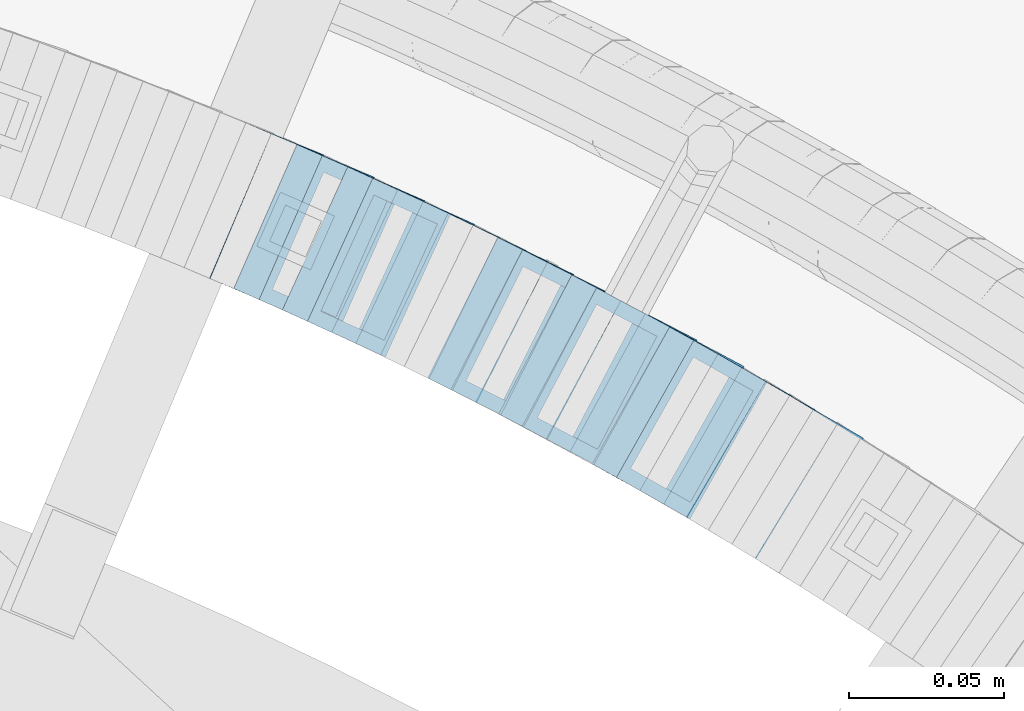
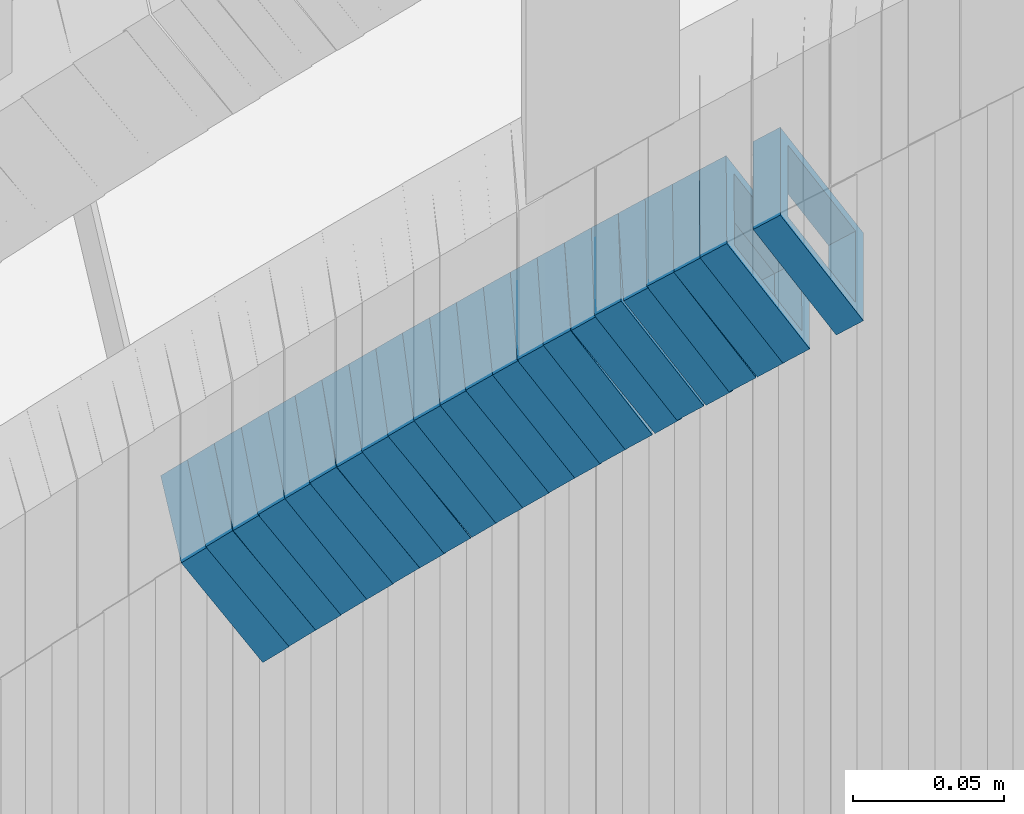
# One storey, part 752 of 975: 22 members.
"""IFC2X3 building model written with IfcOpenShell, lengths in millimetres."""

from ifc_helpers import new_model, si_unit, frame, origin_with_axes, place, context, subcontext, project, spatial, faceted_brep, material, type_object, element, save


model = new_model("IFC2X3")

# Units and contexts
model_context = context("Model", 3, precision=1e-05, world=origin_with_axes())
body_context = subcontext(model_context, "Body", "Model", "MODEL_VIEW")
ifc_project = project(units=[si_unit("LENGTHUNIT", "METRE", prefix="MILLI"), si_unit("AREAUNIT", "SQUARE_METRE"), si_unit("VOLUMEUNIT", "CUBIC_METRE"), si_unit("MASSUNIT", "GRAM", prefix="KILO"), si_unit("TIMEUNIT", "SECOND"), si_unit("PLANEANGLEUNIT", "RADIAN"), si_unit("SOLIDANGLEUNIT", "STERADIAN"), si_unit("THERMODYNAMICTEMPERATUREUNIT", "DEGREE_CELSIUS"), si_unit("LUMINOUSINTENSITYUNIT", "LUMEN")], contexts=[model_context])

# Site, building, storey
site_placement = place(None, origin_with_axes())
site = spatial("IfcSite", under=ifc_project, at=site_placement, CompositionType="ELEMENT")
building_placement = place(site_placement, origin_with_axes())
building = spatial("IfcBuilding", under=site, at=building_placement, Name="Undefined", CompositionType="ELEMENT")
storey_placement = place(building_placement, origin_with_axes())
storey = spatial("IfcBuildingStorey", under=building, at=storey_placement, Name="Undefined", CompositionType="ELEMENT", Elevation=0.0)

# Members
ifc_material = material()
member_type = type_object("IfcMemberType", Name="HSS2X2X.188_TUBES", PredefinedType="NOTDEFINED")
member_1_placement = place(storey_placement, frame((35434.9974360442, 4612.49057627026, 1515.73278679352), z_axis=(0.496138938203221, 0.868243142212238, 4.57307578471955e-11), x_axis=(0.730391194976154, -0.417366396986292, 0.540679195982226)))
element("IfcMember", 1, at=member_1_placement, inside=storey, type_object=member_type, material=ifc_material, Name="WALL", ObjectType="HSS2X2X.188_TUBES", context=body_context, shape_type="Brep", body=[
    faceted_brep([(0.0, 20.6374999999753, -20.6375000000298), (0.0, -20.6375000000153, -20.6375000000153), (10.5422957651572, -20.6374999999771, -20.6374999999534), (10.5422957651481, 20.6375000000153, -20.6374999999789), (0.0, -20.6374999999825, 20.6375000000335), (10.5422957651535, -20.6374999999971, 20.6375000000298), (0.0, 20.6375000000116, 20.6375000000189), (10.5422957651444, 20.6374999999971, 20.6375000000044), (0.0, 25.3999999999724, -25.4000000000342), (0.0, 25.400000000016, 25.4000000000196), (10.5422957651426, 25.3999999999924, 25.3999999999905), (10.5422957651463, 25.4000000000178, -25.3999999999833), (0.0, -25.399999999976, 25.4000000000378), (10.5422957651499, -25.3999999999996, 25.4000000000269), (0.0, -25.400000000016, -25.4000000000196), (10.5422957651554, -25.3999999999742, -25.3999999999469)], [[[0, 1, 2, 3]], [[1, 4, 5, 2]], [[4, 6, 7, 5]], [[6, 0, 3, 7]], [[8, 9, 10, 11]], [[9, 12, 13, 10]], [[12, 14, 15, 13]], [[14, 8, 11, 15]], [[13, 15, 11, 10], [5, 7, 3, 2]], [[14, 12, 9, 8], [6, 4, 1, 0]]]),
])
member_2_placement = place(storey_placement, frame((35450.2959705193, 4603.58334832504, 1527.14601812941), z_axis=(0.499722453606285, 0.866185585981269, 3.44271711583132e-10), x_axis=(0.728209106903487, -0.420120638944157, 0.541488822928026)))
element("IfcMember", 2, at=member_2_placement, inside=storey, type_object=member_type, material=ifc_material, Name="WALL", ObjectType="HSS2X2X.188_TUBES", context=body_context, shape_type="Brep", body=[
    faceted_brep([(0.0, 20.6374999999753, -20.6375000000298), (0.0, -20.6375000000153, -20.6375000000153), (10.7093417165161, -20.637499999968, -20.6374999999534), (10.709341716436, 20.6374999999898, -20.6375000000116), (0.0, -20.6374999999825, 20.6375000000335), (10.7093417164688, -20.6374999999971, 20.6375000000153), (0.0, 20.6375000000116, 20.6375000000189), (10.7093417163924, 20.6374999999643, 20.6374999999571), (0.0, 25.3999999999724, -25.4000000000342), (0.0, 25.400000000016, 25.4000000000196), (10.7093417163815, 25.3999999999542, 25.3999999999469), (10.7093417164288, 25.3999999999869, -25.4000000000196), (0.0, -25.399999999976, 25.4000000000378), (10.7093417164724, -25.3999999999942, 25.4000000000196), (0.0, -25.400000000016, -25.4000000000196), (10.709341716527, -25.3999999999578, -25.3999999999432)], [[[0, 1, 2, 3]], [[1, 4, 5, 2]], [[4, 6, 7, 5]], [[6, 0, 3, 7]], [[8, 9, 10, 11]], [[9, 12, 13, 10]], [[12, 14, 15, 13]], [[14, 8, 11, 15]], [[13, 15, 11, 10], [5, 7, 3, 2]], [[14, 12, 9, 8], [6, 4, 1, 0]]]),
])
member_3_placement = place(storey_placement, frame((35427.4220188738, 4616.85079483736, 1509.9806746727), z_axis=(0.491321186669673, 0.870978467890857, -1.51605718201608e-10), x_axis=(0.731050131101486, -0.412387253057095, 0.543601379075259)))
element("IfcMember", 3, at=member_3_placement, inside=storey, type_object=member_type, material=ifc_material, Name="WALL", ObjectType="HSS2X2X.188_TUBES", context=body_context, shape_type="Brep", body=[
    faceted_brep([(0.0, 20.6374999999753, -20.6375000000298), (0.0, -20.6375000000153, -20.6375000000153), (10.6709887076922, -20.6374999999844, -20.6374999999825), (10.6709887076995, 20.6375000000171, -20.6374999999753), (0.0, -20.6374999999825, 20.6375000000335), (10.6709887076922, -20.6374999999971, 20.6375000000153), (0.0, 20.6375000000116, 20.6375000000189), (10.6709887076941, 20.6375000000025, 20.6375000000189), (0.0, 25.3999999999724, -25.4000000000342), (0.0, 25.400000000016, 25.4000000000196), (10.6709887076959, 25.3999999999996, 25.4000000000233), (10.6709887077013, 25.4000000000178, -25.3999999999724), (0.0, -25.399999999976, 25.4000000000378), (10.6709887076904, -25.3999999999978, 25.400000000016), (0.0, -25.400000000016, -25.4000000000196), (10.6709887076959, -25.3999999999796, -25.3999999999796)], [[[0, 1, 2, 3]], [[1, 4, 5, 2]], [[4, 6, 7, 5]], [[6, 0, 3, 7]], [[8, 9, 10, 11]], [[9, 12, 13, 10]], [[12, 14, 15, 13]], [[14, 8, 11, 15]], [[13, 15, 11, 10], [5, 7, 3, 2]], [[14, 12, 9, 8], [6, 4, 1, 0]]]),
])
member_4_placement = place(storey_placement, frame((35419.4748254217, 4621.33382704107, 1504.17216907421), z_axis=(0.491321186669673, 0.870978467890857, -1.51605718201608e-10), x_axis=(0.734770841275006, -0.414486115154973, 0.536947922200801)))
element("IfcMember", 4, at=member_4_placement, inside=storey, type_object=member_type, material=ifc_material, Name="WALL", ObjectType="HSS2X2X.188_TUBES", context=body_context, shape_type="Brep", body=[
    faceted_brep([(0.0, 20.6374999999753, -20.6375000000298), (0.0, -20.6375000000153, -20.6375000000153), (10.6216759506497, -20.637499999968, -20.6374999999534), (10.6216759506497, 20.6375000000262, -20.6374999999643), (0.0, -20.6374999999825, 20.6375000000335), (10.6216759506169, -20.6374999999935, 20.637500000008), (0.0, 20.6375000000116, 20.6375000000189), (10.6216759506242, 20.6375000000007, 20.6374999999971), (0.0, 25.3999999999724, -25.4000000000342), (0.0, 25.400000000016, 25.4000000000196), (10.6216759506169, 25.3999999999978, 25.3999999999869), (10.6216759506533, 25.4000000000269, -25.3999999999614), (0.0, -25.399999999976, 25.4000000000378), (10.6216759506242, -25.3999999999942, 25.4000000000051), (0.0, -25.400000000016, -25.4000000000196), (10.6216759506569, -25.3999999999614, -25.3999999999432)], [[[0, 1, 2, 3]], [[1, 4, 5, 2]], [[4, 6, 7, 5]], [[6, 0, 3, 7]], [[8, 9, 10, 11]], [[9, 12, 13, 10]], [[12, 14, 15, 13]], [[14, 8, 11, 15]], [[13, 15, 11, 10], [5, 7, 3, 2]], [[14, 12, 9, 8], [6, 4, 1, 0]]]),
])
member_5_placement = place(storey_placement, frame((35412.3025046159, 4625.52354750214, 1498.4779549158), z_axis=(0.469427602090153, 0.882970965771746, 1.18974867291399e-10), x_axis=(0.744686765943849, -0.3959094199702, 0.537305640959548)))
element("IfcMember", 5, at=member_5_placement, inside=storey, type_object=member_type, material=ifc_material, Name="WALL", ObjectType="HSS2X2X.188_TUBES", context=body_context, shape_type="Brep", body=[
    faceted_brep([(0.0, 20.6374999999753, -20.6375000000298), (0.0, -20.6375000000153, -20.6375000000153), (10.6061303028146, -20.6374999999571, -20.6374999999643), (10.6061303027491, 20.6374999999971, -20.6375000000007), (0.0, -20.6374999999825, 20.6375000000335), (10.6061303027855, -20.6374999999825, 20.6375000000116), (0.0, 20.6375000000116, 20.6375000000189), (10.6061303027236, 20.637499999968, 20.6374999999716), (0.0, 25.3999999999724, -25.4000000000342), (0.0, 25.400000000016, 25.4000000000196), (10.6061303027163, 25.3999999999651, 25.3999999999651), (10.6061303027454, 25.3999999999942, -25.4000000000051), (0.0, -25.399999999976, 25.4000000000378), (10.6061303027891, -25.3999999999796, 25.4000000000124), (0.0, -25.400000000016, -25.4000000000196), (10.6061303028182, -25.3999999999505, -25.3999999999542)], [[[0, 1, 2, 3]], [[1, 4, 5, 2]], [[4, 6, 7, 5]], [[6, 0, 3, 7]], [[8, 9, 10, 11]], [[9, 12, 13, 10]], [[12, 14, 15, 13]], [[14, 8, 11, 15]], [[13, 15, 11, 10], [5, 7, 3, 2]], [[14, 12, 9, 8], [6, 4, 1, 0]]]),
])
member_6_placement = place(storey_placement, frame((35404.1030910584, 4629.80376584595, 1492.80596512413), z_axis=(0.482780509040982, 0.875741388818714, 7.89789282862329e-11), x_axis=(0.737623694251243, -0.406638703138413, 0.539032699183508)))
element("IfcMember", 6, at=member_6_placement, inside=storey, type_object=member_type, material=ifc_material, Name="WALL", ObjectType="HSS2X2X.188_TUBES", context=body_context, shape_type="Brep", body=[
    faceted_brep([(0.0, 20.6374999999753, -20.6375000000298), (0.0, -20.6375000000153, -20.6375000000153), (10.5744976239494, -20.6375000000207, -20.6375000000335), (10.5744976239657, 20.6375000000098, -20.637500000008), (0.0, -20.6374999999825, 20.6375000000335), (10.5744976239639, -20.6375000000244, 20.6374999999753), (0.0, 20.6375000000116, 20.6375000000189), (10.5744976239803, 20.6374999999989, 20.6374999999935), (0.0, 25.3999999999724, -25.4000000000342), (0.0, 25.400000000016, 25.4000000000196), (10.5744976239857, 25.4000000000051, 25.4000000000015), (10.5744976239675, 25.4000000000124, -25.4000000000051), (0.0, -25.399999999976, 25.4000000000378), (10.5744976239639, -25.4000000000287, 25.3999999999724), (0.0, -25.400000000016, -25.4000000000196), (10.5744976239494, -25.4000000000215, -25.4000000000378)], [[[0, 1, 2, 3]], [[1, 4, 5, 2]], [[4, 6, 7, 5]], [[6, 0, 3, 7]], [[8, 9, 10, 11]], [[9, 12, 13, 10]], [[12, 14, 15, 13]], [[14, 8, 11, 15]], [[13, 15, 11, 10], [5, 7, 3, 2]], [[14, 12, 9, 8], [6, 4, 1, 0]]]),
])
member_7_placement = place(storey_placement, frame((35397.0835716603, 4633.82500833659, 1487.11953505789), z_axis=(0.46064508089183, 0.887584423843816, -1.56837813847233e-11), x_axis=(0.743630284592201, -0.38593470478849, 0.545956411700736)))
element("IfcMember", 7, at=member_7_placement, inside=storey, type_object=member_type, material=ifc_material, Name="WALL", ObjectType="HSS2X2X.188_TUBES", context=body_context, shape_type="Brep", body=[
    faceted_brep([(0.0, 20.6374999999753, -20.6375000000298), (0.0, -20.6375000000153, -20.6375000000153), (10.6216759506497, -20.637499999968, -20.6374999999534), (10.6216759506497, 20.6375000000262, -20.6374999999643), (0.0, -20.6374999999825, 20.6375000000335), (10.6216759506169, -20.6374999999935, 20.637500000008), (0.0, 20.6375000000116, 20.6375000000189), (10.6216759506242, 20.6375000000007, 20.6374999999971), (0.0, 25.3999999999724, -25.4000000000342), (0.0, 25.400000000016, 25.4000000000196), (10.6216759506169, 25.3999999999978, 25.3999999999869), (10.6216759506533, 25.4000000000269, -25.3999999999614), (0.0, -25.399999999976, 25.4000000000378), (10.6216759506242, -25.3999999999942, 25.4000000000051), (0.0, -25.400000000016, -25.4000000000196), (10.6216759506569, -25.3999999999614, -25.3999999999432)], [[[0, 1, 2, 3]], [[1, 4, 5, 2]], [[4, 6, 7, 5]], [[6, 0, 3, 7]], [[8, 9, 10, 11]], [[9, 12, 13, 10]], [[12, 14, 15, 13]], [[14, 8, 11, 15]], [[13, 15, 11, 10], [5, 7, 3, 2]], [[14, 12, 9, 8], [6, 4, 1, 0]]]),
])
member_8_placement = place(storey_placement, frame((35388.6678405396, 4638.16894075791, 1481.2174760001), z_axis=(0.464833898973127, 0.88539790284676, 2.99266957881628e-11), x_axis=(0.748841799918479, -0.393141944957117, 0.533549781941843)))
element("IfcMember", 8, at=member_8_placement, inside=storey, type_object=member_type, material=ifc_material, Name="WALL", ObjectType="HSS2X2X.188_TUBES", context=body_context, shape_type="Brep", body=[
    faceted_brep([(0.0, 20.6374999999753, -20.6375000000298), (0.0, -20.6375000000153, -20.6375000000153), (10.6831643251735, -20.6375000000498, -20.6375000000953), (10.6831643252044, 20.637499999988, -20.6375000000226), (0.0, -20.6374999999825, 20.6375000000335), (10.6831643251935, -20.6375000000135, 20.637499999968), (0.0, 20.6375000000116, 20.6375000000189), (10.6831643252244, 20.6375000000226, 20.6375000000407), (0.0, 25.3999999999724, -25.4000000000342), (0.0, 25.400000000016, 25.4000000000196), (10.6831643252317, 25.4000000000306, 25.4000000000597), (10.6831643252044, 25.3999999999905, -25.4000000000196), (0.0, -25.399999999976, 25.4000000000378), (10.6831643251917, -25.400000000016, 25.3999999999614), (0.0, -25.400000000016, -25.4000000000196), (10.6831643251644, -25.400000000056, -25.4000000001179)], [[[0, 1, 2, 3]], [[1, 4, 5, 2]], [[4, 6, 7, 5]], [[6, 0, 3, 7]], [[8, 9, 10, 11]], [[9, 12, 13, 10]], [[12, 14, 15, 13]], [[14, 8, 11, 15]], [[13, 15, 11, 10], [5, 7, 3, 2]], [[14, 12, 9, 8], [6, 4, 1, 0]]]),
])
member_9_placement = place(storey_placement, frame((35381.0334607013, 4642.20291402418, 1475.61027951396), z_axis=(0.46064508089183, 0.887584423843816, -1.56837813847233e-11), x_axis=(0.747448139909826, -0.387916122952996, 0.539298024934689)))
element("IfcMember", 9, at=member_9_placement, inside=storey, type_object=member_type, material=ifc_material, Name="WALL", ObjectType="HSS2X2X.188_TUBES", context=body_context, shape_type="Brep", body=[
    faceted_brep([(0.0, 20.6374999999753, -20.6375000000298), (0.0, -20.6375000000153, -20.6375000000153), (10.5744976239494, -20.6375000000207, -20.6375000000335), (10.5744976239657, 20.6375000000098, -20.637500000008), (0.0, -20.6374999999825, 20.6375000000335), (10.5744976239639, -20.6375000000244, 20.6374999999753), (0.0, 20.6375000000116, 20.6375000000189), (10.5744976239803, 20.6374999999989, 20.6374999999935), (0.0, 25.3999999999724, -25.4000000000342), (0.0, 25.400000000016, 25.4000000000196), (10.5744976239857, 25.4000000000051, 25.4000000000015), (10.5744976239675, 25.4000000000124, -25.4000000000051), (0.0, -25.399999999976, 25.4000000000378), (10.5744976239639, -25.4000000000287, 25.3999999999724), (0.0, -25.400000000016, -25.4000000000196), (10.5744976239494, -25.4000000000215, -25.4000000000378)], [[[0, 1, 2, 3]], [[1, 4, 5, 2]], [[4, 6, 7, 5]], [[6, 0, 3, 7]], [[8, 9, 10, 11]], [[9, 12, 13, 10]], [[12, 14, 15, 13]], [[14, 8, 11, 15]], [[13, 15, 11, 10], [5, 7, 3, 2]], [[14, 12, 9, 8], [6, 4, 1, 0]]]),
])
member_10_placement = place(storey_placement, frame((35373.4258024925, 4646.23437016647, 1469.87988730664), z_axis=(0.447213595463116, 0.894427191018337, -1.29375166579848e-10), x_axis=(0.754280757630217, -0.377140378815194, 0.53742503973663)))
element("IfcMember", 10, at=member_10_placement, inside=storey, type_object=member_type, material=ifc_material, Name="WALL", ObjectType="HSS2X2X.188_TUBES", context=body_context, shape_type="Brep", body=[
    faceted_brep([(0.0, 20.6374999999753, -20.6375000000298), (0.0, -20.6375000000153, -20.6375000000153), (10.6061303028146, -20.6374999999571, -20.6374999999643), (10.6061303027491, 20.6374999999971, -20.6375000000007), (0.0, -20.6374999999825, 20.6375000000335), (10.6061303027855, -20.6374999999825, 20.6375000000116), (0.0, 20.6375000000116, 20.6375000000189), (10.6061303027236, 20.637499999968, 20.6374999999716), (0.0, 25.3999999999724, -25.4000000000342), (0.0, 25.400000000016, 25.4000000000196), (10.6061303027163, 25.3999999999651, 25.3999999999651), (10.6061303027454, 25.3999999999942, -25.4000000000051), (0.0, -25.399999999976, 25.4000000000378), (10.6061303027891, -25.3999999999796, 25.4000000000124), (0.0, -25.400000000016, -25.4000000000196), (10.6061303028182, -25.3999999999505, -25.3999999999542)], [[[0, 1, 2, 3]], [[1, 4, 5, 2]], [[4, 6, 7, 5]], [[6, 0, 3, 7]], [[8, 9, 10, 11]], [[9, 12, 13, 10]], [[12, 14, 15, 13]], [[14, 8, 11, 15]], [[13, 15, 11, 10], [5, 7, 3, 2]], [[14, 12, 9, 8], [6, 4, 1, 0]]]),
])
member_11_placement = place(storey_placement, frame((35365.5769820395, 4650.15878039297, 1464.1885452034), z_axis=(0.447213595463116, 0.894427191018337, -1.29375166579848e-10), x_axis=(0.750454514252734, -0.375227257126282, 0.544079523183129)))
element("IfcMember", 11, at=member_11_placement, inside=storey, type_object=member_type, material=ifc_material, Name="WALL", ObjectType="HSS2X2X.188_TUBES", context=body_context, shape_type="Brep", body=[
    faceted_brep([(0.0, 20.6374999999753, -20.6375000000298), (0.0, -20.6375000000153, -20.6375000000153), (10.6625512894789, -20.6374999999625, -20.6374999999389), (10.6625512893879, 20.6374999999789, -20.6375000000371), (0.0, -20.6374999999825, 20.6375000000335), (10.6625512894352, -20.6374999999989, 20.6375000000153), (0.0, 20.6375000000116, 20.6375000000189), (10.6625512893443, 20.6374999999443, 20.6374999999134), (0.0, 25.3999999999724, -25.4000000000342), (0.0, 25.400000000016, 25.4000000000196), (10.6625512893297, 25.3999999999342, 25.3999999998996), (10.6625512893916, 25.399999999976, -25.4000000000415), (0.0, -25.399999999976, 25.4000000000378), (10.6625512894389, -25.399999999996, 25.400000000016), (0.0, -25.400000000016, -25.4000000000196), (10.6625512894971, -25.3999999999523, -25.3999999999214)], [[[0, 1, 2, 3]], [[1, 4, 5, 2]], [[4, 6, 7, 5]], [[6, 0, 3, 7]], [[8, 9, 10, 11]], [[9, 12, 13, 10]], [[12, 14, 15, 13]], [[14, 8, 11, 15]], [[13, 15, 11, 10], [5, 7, 3, 2]], [[14, 12, 9, 8], [6, 4, 1, 0]]]),
])
member_12_placement = place(storey_placement, frame((35357.7587392916, 4654.12325477763, 1458.41067219573), z_axis=(0.438202247109097, 0.898876404534315, -8.71484644449083e-11), x_axis=(0.756943389157146, -0.369009902076447, 0.539322165111749)))
element("IfcMember", 12, at=member_12_placement, inside=storey, type_object=member_type, material=ifc_material, Name="WALL", ObjectType="HSS2X2X.188_TUBES", context=body_context, shape_type="Brep", body=[
    faceted_brep([(0.0, 20.6374999999753, -20.6375000000298), (0.0, -20.6375000000153, -20.6375000000153), (10.5744976239494, -20.6375000000207, -20.6375000000335), (10.5744976239657, 20.6375000000098, -20.637500000008), (0.0, -20.6374999999825, 20.6375000000335), (10.5744976239639, -20.6375000000244, 20.6374999999753), (0.0, 20.6375000000116, 20.6375000000189), (10.5744976239803, 20.6374999999989, 20.6374999999935), (0.0, 25.3999999999724, -25.4000000000342), (0.0, 25.400000000016, 25.4000000000196), (10.5744976239857, 25.4000000000051, 25.4000000000015), (10.5744976239675, 25.4000000000124, -25.4000000000051), (0.0, -25.399999999976, 25.4000000000378), (10.5744976239639, -25.4000000000287, 25.3999999999724), (0.0, -25.400000000016, -25.4000000000196), (10.5744976239494, -25.4000000000215, -25.4000000000378)], [[[0, 1, 2, 3]], [[1, 4, 5, 2]], [[4, 6, 7, 5]], [[6, 0, 3, 7]], [[8, 9, 10, 11]], [[9, 12, 13, 10]], [[12, 14, 15, 13]], [[14, 8, 11, 15]], [[13, 15, 11, 10], [5, 7, 3, 2]], [[14, 12, 9, 8], [6, 4, 1, 0]]]),
])
member_13_placement = place(storey_placement, frame((35342.1470448302, 4661.74378026491, 1447.05100239252), z_axis=(0.429056814647039, 0.903277504316883, -2.97829501505475e-10), x_axis=(0.75565911600651, -0.358938080003198, 0.547852859004933)))
element("IfcMember", 13, at=member_13_placement, inside=storey, type_object=member_type, material=ifc_material, Name="WALL", ObjectType="HSS2X2X.188_TUBES", context=body_context, shape_type="Brep", body=[
    faceted_brep([(0.0, 20.6374999999753, -20.6375000000298), (0.0, -20.6375000000153, -20.6375000000153), (10.5948100501191, -20.6375000000335, -20.6375000000844), (10.5948100501555, 20.6374999999971, -20.6375000000116), (0.0, -20.6374999999825, 20.6375000000335), (10.5948100501446, -20.6375000000098, 20.6374999999571), (0.0, 20.6375000000116, 20.6375000000189), (10.5948100501828, 20.6375000000189, 20.6375000000298), (0.0, 25.3999999999724, -25.4000000000342), (0.0, 25.400000000016, 25.4000000000196), (10.5948100501919, 25.4000000000251, 25.4000000000451), (10.5948100501591, 25.3999999999978, -25.4000000000051), (0.0, -25.399999999976, 25.4000000000378), (10.5948100501482, -25.4000000000106, 25.3999999999578), (0.0, -25.400000000016, -25.4000000000196), (10.5948100501118, -25.4000000000378, -25.400000000096)], [[[0, 1, 2, 3]], [[1, 4, 5, 2]], [[4, 6, 7, 5]], [[6, 0, 3, 7]], [[8, 9, 10, 11]], [[9, 12, 13, 10]], [[12, 14, 15, 13]], [[14, 8, 11, 15]], [[13, 15, 11, 10], [5, 7, 3, 2]], [[14, 12, 9, 8], [6, 4, 1, 0]]]),
])
member_14_placement = place(storey_placement, frame((35349.7112724843, 4658.07173522613, 1452.64843312844), z_axis=(0.433815618951201, 0.901001669673251, 6.19982074567816e-11), x_axis=(0.760940849966011, -0.366378927983755, 0.535476893976275)))
element("IfcMember", 14, at=member_14_placement, inside=storey, type_object=member_type, material=ifc_material, Name="WALL", ObjectType="HSS2X2X.188_TUBES", context=body_context, shape_type="Brep", body=[
    faceted_brep([(0.0, 20.6374999999753, -20.6375000000298), (0.0, -20.6375000000153, -20.6375000000153), (10.6395488625676, -20.6374999999771, -20.6374999999716), (10.6395488625531, 20.6374999999916, -20.6375000000189), (0.0, -20.6374999999825, 20.6375000000335), (10.6395488625731, -20.6374999999844, 20.6375000000153), (0.0, 20.6375000000116, 20.6375000000189), (10.6395488625585, 20.6374999999825, 20.637499999968), (0.0, 25.3999999999724, -25.4000000000342), (0.0, 25.400000000016, 25.4000000000196), (10.6395488625567, 25.3999999999778, 25.3999999999614), (10.6395488625494, 25.3999999999887, -25.4000000000233), (0.0, -25.399999999976, 25.4000000000378), (10.6395488625749, -25.3999999999851, 25.400000000016), (0.0, -25.400000000016, -25.4000000000196), (10.6395488625658, -25.399999999976, -25.3999999999687)], [[[0, 1, 2, 3]], [[1, 4, 5, 2]], [[4, 6, 7, 5]], [[6, 0, 3, 7]], [[8, 9, 10, 11]], [[9, 12, 13, 10]], [[12, 14, 15, 13]], [[14, 8, 11, 15]], [[13, 15, 11, 10], [5, 7, 3, 2]], [[14, 12, 9, 8], [6, 4, 1, 0]]]),
])
member_15_placement = place(storey_placement, frame((35333.9431458108, 4665.6659105841, 1441.17795491567), z_axis=(0.424720210825697, 0.905324661387381, 1.0447547538206e-10), x_axis=(0.763539595237658, -0.358203761111365, 0.537305641167097)))
element("IfcMember", 15, at=member_15_placement, inside=storey, type_object=member_type, material=ifc_material, Name="WALL", ObjectType="HSS2X2X.188_TUBES", context=body_context, shape_type="Brep", body=[
    faceted_brep([(0.0, 20.6374999999753, -20.6375000000298), (0.0, -20.6375000000153, -20.6375000000153), (10.6061303028146, -20.6374999999571, -20.6374999999643), (10.6061303027491, 20.6374999999971, -20.6375000000007), (0.0, -20.6374999999825, 20.6375000000335), (10.6061303027855, -20.6374999999825, 20.6375000000116), (0.0, 20.6375000000116, 20.6375000000189), (10.6061303027236, 20.637499999968, 20.6374999999716), (0.0, 25.3999999999724, -25.4000000000342), (0.0, 25.400000000016, 25.4000000000196), (10.6061303027163, 25.3999999999651, 25.3999999999651), (10.6061303027454, 25.3999999999942, -25.4000000000051), (0.0, -25.399999999976, 25.4000000000378), (10.6061303027891, -25.3999999999796, 25.4000000000124), (0.0, -25.400000000016, -25.4000000000196), (10.6061303028182, -25.3999999999505, -25.3999999999542)], [[[0, 1, 2, 3]], [[1, 4, 5, 2]], [[4, 6, 7, 5]], [[6, 0, 3, 7]], [[8, 9, 10, 11]], [[9, 12, 13, 10]], [[12, 14, 15, 13]], [[14, 8, 11, 15]], [[13, 15, 11, 10], [5, 7, 3, 2]], [[14, 12, 9, 8], [6, 4, 1, 0]]]),
])
member_16_placement = place(storey_placement, frame((35326.1202964446, 4669.41405141638, 1435.44425173907), z_axis=(0.411288866904863, 0.91150505646437, -1.75959485204658e-10), x_axis=(0.769961537257372, -0.347421669116229, 0.535217166179074)))
element("IfcMember", 16, at=member_16_placement, inside=storey, type_object=member_type, material=ifc_material, Name="WALL", ObjectType="HSS2X2X.188_TUBES", context=body_context, shape_type="Brep", body=[
    faceted_brep([(0.0, 20.6374999999753, -20.6375000000298), (0.0, -20.6375000000153, -20.6375000000153), (10.648004507897, -20.6374999999862, -20.637499999968), (10.6480045078188, 20.6374999999771, -20.6375000000808), (0.0, -20.6374999999825, 20.6375000000335), (10.6480045079406, -20.6374999999698, 20.6375000001062), (0.0, 20.6375000000116, 20.6375000000189), (10.6480045078679, 20.6374999999935, 20.6375000000007), (0.0, 25.3999999999724, -25.4000000000342), (0.0, 25.400000000016, 25.4000000000196), (10.6480045078661, 25.3999999999905, 25.4000000000015), (10.648004507806, 25.3999999999705, -25.4000000000997), (0.0, -25.399999999976, 25.4000000000378), (10.6480045079552, -25.3999999999633, 25.4000000001288), (0.0, -25.400000000016, -25.4000000000196), (10.6480045078988, -25.3999999999814, -25.3999999999651)], [[[0, 1, 2, 3]], [[1, 4, 5, 2]], [[4, 6, 7, 5]], [[6, 0, 3, 7]], [[8, 9, 10, 11]], [[9, 12, 13, 10]], [[12, 14, 15, 13]], [[14, 8, 11, 15]], [[13, 15, 11, 10], [5, 7, 3, 2]], [[14, 12, 9, 8], [6, 4, 1, 0]]]),
])
member_17_placement = place(storey_placement, frame((35318.1311694488, 4672.99407982349, 1429.81633482316), z_axis=(0.415494357697142, 0.909595755663932, 4.42396412836388e-11), x_axis=(0.762186280713477, -0.348159164869278, 0.545763015795028)))
element("IfcMember", 17, at=member_17_placement, inside=storey, type_object=member_type, material=ifc_material, Name="WALL", ObjectType="HSS2X2X.188_TUBES", context=body_context, shape_type="Brep", body=[
    faceted_brep([(0.0, 20.6374999999753, -20.6375000000298), (0.0, -20.6375000000153, -20.6375000000153), (10.6348483769107, -20.637499999988, -20.6374999999825), (10.6348483768415, 20.6374999999734, -20.6375000001026), (0.0, -20.6374999999825, 20.6375000000335), (10.6348483769852, -20.6374999999589, 20.6375000001462), (0.0, 20.6375000000116, 20.6375000000189), (10.6348483769161, 20.6375000000044, 20.6375000000226), (0.0, 25.3999999999724, -25.4000000000342), (0.0, 25.400000000016, 25.4000000000196), (10.6348483769179, 25.4000000000015, 25.4000000000233), (10.6348483768288, 25.3999999999669, -25.4000000001324), (0.0, -25.399999999976, 25.4000000000378), (10.6348483769998, -25.3999999999505, 25.4000000001688), (0.0, -25.400000000016, -25.4000000000196), (10.6348483769107, -25.3999999999887, -25.3999999999833)], [[[0, 1, 2, 3]], [[1, 4, 5, 2]], [[4, 6, 7, 5]], [[6, 0, 3, 7]], [[8, 9, 10, 11]], [[9, 12, 13, 10]], [[12, 14, 15, 13]], [[14, 8, 11, 15]], [[13, 15, 11, 10], [5, 7, 3, 2]], [[14, 12, 9, 8], [6, 4, 1, 0]]]),
])
member_18_placement = place(storey_placement, frame((35294.0210749649, 4683.87601557448, 1412.43629381851), z_axis=(0.388553247225959, 0.921426271640962, 2.20024048758205e-10), x_axis=(0.778630818029036, -0.328338297012357, 0.534722369020092)))
element("IfcMember", 18, at=member_18_placement, inside=storey, type_object=member_type, material=ifc_material, Name="WALL", ObjectType="HSS2X2X.188_TUBES", context=body_context, shape_type="Brep", body=[
    faceted_brep([(0.0, 20.6374999999753, -20.6375000000298), (0.0, -20.6375000000153, -20.6375000000153), (10.6625512894789, -20.6374999999625, -20.6374999999389), (10.6625512893879, 20.6374999999789, -20.6375000000371), (0.0, -20.6374999999825, 20.6375000000335), (10.6625512894352, -20.6374999999989, 20.6375000000153), (0.0, 20.6375000000116, 20.6375000000189), (10.6625512893443, 20.6374999999443, 20.6374999999134), (0.0, 25.3999999999724, -25.4000000000342), (0.0, 25.400000000016, 25.4000000000196), (10.6625512893297, 25.3999999999342, 25.3999999998996), (10.6625512893916, 25.399999999976, -25.4000000000415), (0.0, -25.399999999976, 25.4000000000378), (10.6625512894389, -25.399999999996, 25.400000000016), (0.0, -25.400000000016, -25.4000000000196), (10.6625512894971, -25.3999999999523, -25.3999999999214)], [[[0, 1, 2, 3]], [[1, 4, 5, 2]], [[4, 6, 7, 5]], [[6, 0, 3, 7]], [[8, 9, 10, 11]], [[9, 12, 13, 10]], [[12, 14, 15, 13]], [[14, 8, 11, 15]], [[13, 15, 11, 10], [5, 7, 3, 2]], [[14, 12, 9, 8], [6, 4, 1, 0]]]),
])
member_19_placement = place(storey_placement, frame((35302.1077480846, 4680.2497268279, 1418.28067467248), z_axis=(0.401990061785647, 0.915644030300843, 1.00948909675935e-10), x_axis=(0.768539881106599, -0.337407753046733, 0.543601379075337)))
element("IfcMember", 19, at=member_19_placement, inside=storey, type_object=member_type, material=ifc_material, Name="WALL", ObjectType="HSS2X2X.188_TUBES", context=body_context, shape_type="Brep", body=[
    faceted_brep([(0.0, 20.6374999999753, -20.6375000000298), (0.0, -20.6375000000153, -20.6375000000153), (10.6709887076922, -20.6374999999844, -20.6374999999825), (10.6709887076995, 20.6375000000171, -20.6374999999753), (0.0, -20.6374999999825, 20.6375000000335), (10.6709887076922, -20.6374999999971, 20.6375000000153), (0.0, 20.6375000000116, 20.6375000000189), (10.6709887076941, 20.6375000000025, 20.6375000000189), (0.0, 25.3999999999724, -25.4000000000342), (0.0, 25.400000000016, 25.4000000000196), (10.6709887076959, 25.3999999999996, 25.4000000000233), (10.6709887077013, 25.4000000000178, -25.3999999999724), (0.0, -25.399999999976, 25.4000000000378), (10.6709887076904, -25.3999999999978, 25.400000000016), (0.0, -25.400000000016, -25.4000000000196), (10.6709887076959, -25.3999999999796, -25.3999999999796)], [[[0, 1, 2, 3]], [[1, 4, 5, 2]], [[4, 6, 7, 5]], [[6, 0, 3, 7]], [[8, 9, 10, 11]], [[9, 12, 13, 10]], [[12, 14, 15, 13]], [[14, 8, 11, 15]], [[13, 15, 11, 10], [5, 7, 3, 2]], [[14, 12, 9, 8], [6, 4, 1, 0]]]),
])
member_20_placement = place(storey_placement, frame((35310.1530062504, 4676.71766226735, 1423.97216907396), z_axis=(0.401990061785647, 0.915644030300843, 1.00948909675935e-10), x_axis=(0.772451396997885, -0.339125003999099, 0.536947921998611)))
element("IfcMember", 20, at=member_20_placement, inside=storey, type_object=member_type, material=ifc_material, Name="WALL", ObjectType="HSS2X2X.188_TUBES", context=body_context, shape_type="Brep", body=[
    faceted_brep([(0.0, 20.6374999999753, -20.6375000000298), (0.0, -20.6375000000153, -20.6375000000153), (10.6216759506497, -20.637499999968, -20.6374999999534), (10.6216759506497, 20.6375000000262, -20.6374999999643), (0.0, -20.6374999999825, 20.6375000000335), (10.6216759506169, -20.6374999999935, 20.637500000008), (0.0, 20.6375000000116, 20.6375000000189), (10.6216759506242, 20.6375000000007, 20.6374999999971), (0.0, 25.3999999999724, -25.4000000000342), (0.0, 25.400000000016, 25.4000000000196), (10.6216759506169, 25.3999999999978, 25.3999999999869), (10.6216759506533, 25.4000000000269, -25.3999999999614), (0.0, -25.399999999976, 25.4000000000378), (10.6216759506242, -25.3999999999942, 25.4000000000051), (0.0, -25.400000000016, -25.4000000000196), (10.6216759506569, -25.3999999999614, -25.3999999999432)], [[[0, 1, 2, 3]], [[1, 4, 5, 2]], [[4, 6, 7, 5]], [[6, 0, 3, 7]], [[8, 9, 10, 11]], [[9, 12, 13, 10]], [[12, 14, 15, 13]], [[14, 8, 11, 15]], [[13, 15, 11, 10], [5, 7, 3, 2]], [[14, 12, 9, 8], [6, 4, 1, 0]]]),
])
member_21_placement = place(storey_placement, frame((35285.943263306, 4687.25924231157, 1406.80875432571), z_axis=(0.392565198227756, 0.919724178838636, -8.87393980519845e-11), x_axis=(0.770947774111805, -0.329063074047623, 0.545304523078969)))
element("IfcMember", 21, at=member_21_placement, inside=storey, type_object=member_type, material=ifc_material, Name="WALL", ObjectType="HSS2X2X.188_TUBES", context=body_context, shape_type="Brep", body=[
    faceted_brep([(0.0, 20.6374999999753, -20.6375000000298), (0.0, -20.6375000000153, -20.6375000000153), (10.6395488625676, -20.6374999999771, -20.6374999999716), (10.6395488625531, 20.6374999999916, -20.6375000000189), (0.0, -20.6374999999825, 20.6375000000335), (10.6395488625731, -20.6374999999844, 20.6375000000153), (0.0, 20.6375000000116, 20.6375000000189), (10.6395488625585, 20.6374999999825, 20.637499999968), (0.0, 25.3999999999724, -25.4000000000342), (0.0, 25.400000000016, 25.4000000000196), (10.6395488625567, 25.3999999999778, 25.3999999999614), (10.6395488625494, 25.3999999999887, -25.4000000000233), (0.0, -25.399999999976, 25.4000000000378), (10.6395488625749, -25.3999999999851, 25.400000000016), (0.0, -25.400000000016, -25.4000000000196), (10.6395488625658, -25.399999999976, -25.3999999999687)], [[[0, 1, 2, 3]], [[1, 4, 5, 2]], [[4, 6, 7, 5]], [[6, 0, 3, 7]], [[8, 9, 10, 11]], [[9, 12, 13, 10]], [[12, 14, 15, 13]], [[14, 8, 11, 15]], [[13, 15, 11, 10], [5, 7, 3, 2]], [[14, 12, 9, 8], [6, 4, 1, 0]]]),
])
member_22_placement = place(storey_placement, frame((35277.8539152076, 4690.78900324378, 1400.96256360759), z_axis=(0.379066925316801, 0.925369259339679, -5.31522346136625e-11), x_axis=(0.781005694706522, -0.319930043879788, 0.536353308798463)))
element("IfcMember", 22, at=member_22_placement, inside=storey, type_object=member_type, material=ifc_material, Name="WALL", ObjectType="HSS2X2X.188_TUBES", context=body_context, shape_type="Brep", body=[
    faceted_brep([(0.0, 20.6374999999753, -20.6375000000298), (0.0, -20.6375000000153, -20.6375000000153), (10.6348483769107, -20.637499999988, -20.6374999999825), (10.6348483768415, 20.6374999999734, -20.6375000001026), (0.0, -20.6374999999825, 20.6375000000335), (10.6348483769852, -20.6374999999589, 20.6375000001462), (0.0, 20.6375000000116, 20.6375000000189), (10.6348483769161, 20.6375000000044, 20.6375000000226), (0.0, 25.3999999999724, -25.4000000000342), (0.0, 25.400000000016, 25.4000000000196), (10.6348483769179, 25.4000000000015, 25.4000000000233), (10.6348483768288, 25.3999999999669, -25.4000000001324), (0.0, -25.399999999976, 25.4000000000378), (10.6348483769998, -25.3999999999505, 25.4000000001688), (0.0, -25.400000000016, -25.4000000000196), (10.6348483769107, -25.3999999999887, -25.3999999999833)], [[[0, 1, 2, 3]], [[1, 4, 5, 2]], [[4, 6, 7, 5]], [[6, 0, 3, 7]], [[8, 9, 10, 11]], [[9, 12, 13, 10]], [[12, 14, 15, 13]], [[14, 8, 11, 15]], [[13, 15, 11, 10], [5, 7, 3, 2]], [[14, 12, 9, 8], [6, 4, 1, 0]]]),
])

save(model, "model.ifc")
